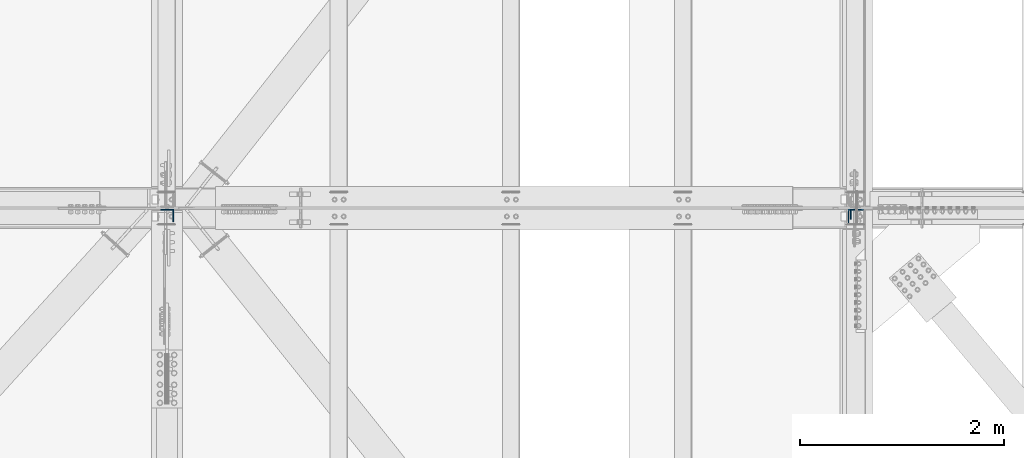
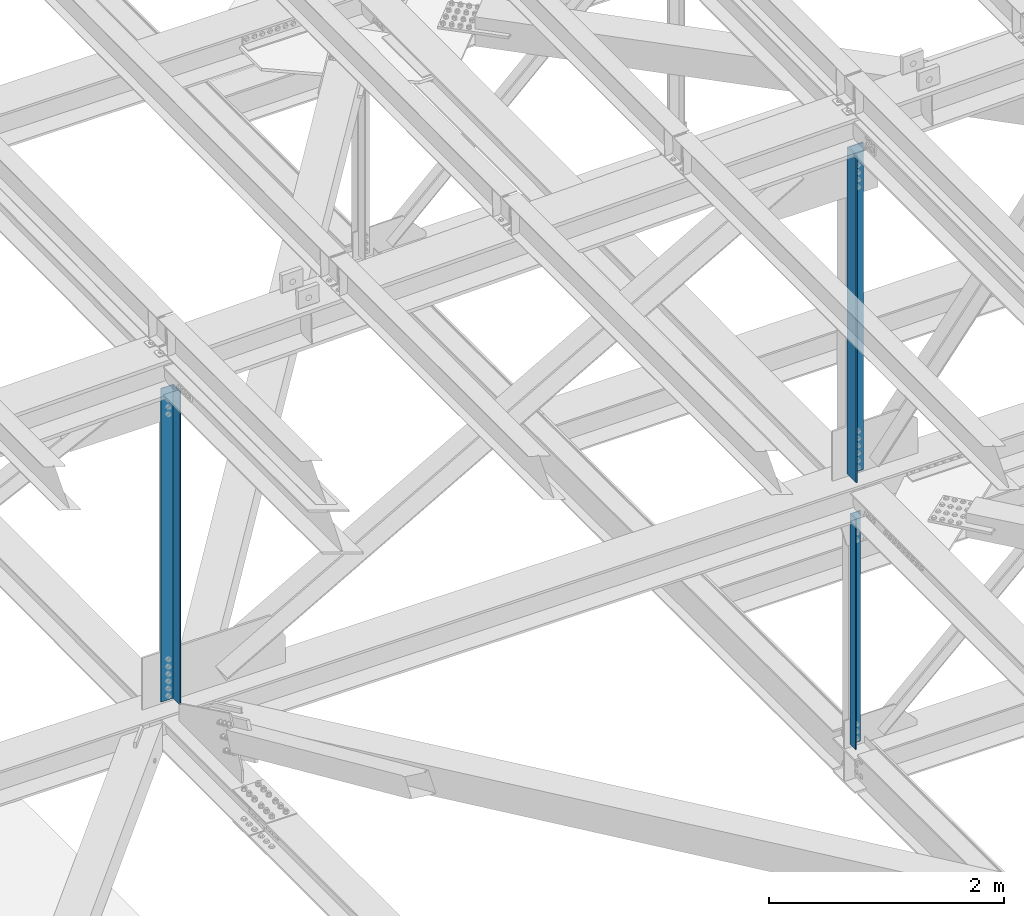
# One storey, part 1334 of 3843: 3 columns, 3 elements without a shape of their own.
"""IFC2X3 building model written with IfcOpenShell, lengths in millimetres."""

from ifc_helpers import new_model, si_unit, frame, origin_with_axes, place, context, subcontext, project, spatial, faceted_brep, material, type_object, element, aggregate, save


model = new_model("IFC2X3")

# Units and contexts
model_context = context("Model", 3, precision=1e-05, world=origin_with_axes())
body_context = subcontext(model_context, "Body", "Model", "MODEL_VIEW")
ifc_project = project(units=[si_unit("LENGTHUNIT", "METRE", prefix="MILLI"), si_unit("AREAUNIT", "SQUARE_METRE"), si_unit("VOLUMEUNIT", "CUBIC_METRE"), si_unit("MASSUNIT", "GRAM", prefix="KILO"), si_unit("TIMEUNIT", "SECOND"), si_unit("PLANEANGLEUNIT", "RADIAN"), si_unit("SOLIDANGLEUNIT", "STERADIAN"), si_unit("THERMODYNAMICTEMPERATUREUNIT", "DEGREE_CELSIUS"), si_unit("LUMINOUSINTENSITYUNIT", "LUMEN")], contexts=[model_context])

# Site, building, storey
site_placement = place(None, origin_with_axes())
site = spatial("IfcSite", under=ifc_project, at=site_placement, CompositionType="ELEMENT")
building_placement = place(site_placement, origin_with_axes())
building = spatial("IfcBuilding", under=site, at=building_placement, Name="Undefined", CompositionType="ELEMENT")
storey_placement = place(building_placement, origin_with_axes())
storey = spatial("IfcBuildingStorey", under=building, at=storey_placement, Name="Undefined", CompositionType="ELEMENT", Elevation=0.0)

# Assembly, column
assembly_1_placement = place(storey_placement, origin_with_axes())
assembly_1 = element("IfcElementAssembly", 1, at=assembly_1_placement, inside=storey, Name="ANGLE", AssemblyPlace="NOTDEFINED", PredefinedType="RIGID_FRAME")
ifc_material = material(Name="STEEL/A572-50")
column_type_1 = type_object("IfcColumnType", Name="L4X4X3/8", PredefinedType="NOTDEFINED")
column_1_placement = place(assembly_1_placement, frame((77012.8000000054, 33785.175, 39446.4754738793), z_axis=(0.0, -1.0, 0.0), x_axis=(0.0, 0.0, 1.0)))
column_1 = element("IfcColumn", 2, at=column_1_placement, type_object=column_type_1, material=ifc_material, Name="ANGLE", ObjectType="L4X4X3/8", context=body_context, shape_type="Brep", body=[
    faceted_brep([(216.00980325316, 50.8000000000029, -50.8000000000029), (216.00980325316, 50.8000000000029, 50.8000000000029), (2610.02346736631, 50.8000000000029, 50.8000000000029), (2610.02346736631, 50.8000000000029, -50.8000000000029), (216.00980325316, 41.2749999999942, 50.8000000000029), (2610.02346736631, 41.2749999999942, 50.8000000000029), (216.00980325316, 41.2749999999942, -41.2750000000015), (2610.02346736631, 41.2749999999942, -41.2750000000015), (216.00980325316, -50.8000000000029, -41.2750000000015), (2610.02346736631, -50.8000000000029, -41.2750000000015), (216.00980325316, -50.8000000000029, -50.8000000000029), (2610.02346736631, -50.8000000000029, -50.8000000000029)], [[[0, 1, 2, 3]], [[1, 4, 5, 2]], [[4, 6, 7, 5]], [[6, 8, 9, 7]], [[8, 10, 11, 9]], [[10, 0, 3, 11]], [[5, 7, 9, 11, 3, 2]], [[10, 8, 6, 4, 1, 0]]]),
])
aggregate(assembly_1, [column_1])

assembly_2_placement = place(storey_placement, origin_with_axes())
assembly_2 = element("IfcElementAssembly", 3, at=assembly_2_placement, inside=storey, Name="ANGLE", AssemblyPlace="NOTDEFINED", PredefinedType="RIGID_FRAME")
column_type_2 = type_object("IfcColumnType", Name="L6X6X1/2", PredefinedType="NOTDEFINED")
column_2_placement = place(assembly_2_placement, frame((77012.8000000005, 33759.775, 42266.073495852), z_axis=(0.0, -1.0, 0.0), x_axis=(0.0, 0.0, 1.0)))
column_2 = element("IfcColumn", 4, at=column_2_placement, type_object=column_type_2, material=ifc_material, Name="ANGLE", ObjectType="L6X6X1/2", context=body_context, shape_type="Brep", body=[
    faceted_brep([(208.907442296171, 76.1999999999971, -76.1999999999971), (208.907442296171, 76.1999999999971, 76.1999999999971), (3606.3579882966, 76.1999999999971, 76.1999999999971), (3606.3579882966, 76.1999999999971, -76.1999999999971), (208.907442296171, 63.5, 76.1999999999971), (3606.3579882966, 63.5, 76.1999999999971), (208.907442296171, 63.5, -63.5), (3606.3579882966, 63.5, -63.5), (208.907442296171, -76.1999999999971, -63.5), (3606.3579882966, -76.1999999999971, -63.5), (208.907442296171, -76.1999999999971, -76.1999999999971), (3606.3579882966, -76.1999999999971, -76.1999999999971)], [[[0, 1, 2, 3]], [[1, 4, 5, 2]], [[4, 6, 7, 5]], [[6, 8, 9, 7]], [[8, 10, 11, 9]], [[10, 0, 3, 11]], [[5, 7, 9, 11, 3, 2]], [[10, 8, 6, 4, 1, 0]]]),
])
aggregate(assembly_2, [column_2])

assembly_3_placement = place(storey_placement, origin_with_axes())
assembly_3 = element("IfcElementAssembly", 5, at=assembly_3_placement, inside=storey, Name="ANGLE", AssemblyPlace="NOTDEFINED", PredefinedType="RIGID_FRAME")
column_type_3 = type_object("IfcColumnType", Name="L5X5X3/8", PredefinedType="NOTDEFINED")
column_3_placement = place(assembly_3_placement, frame((70256.4000000689, 33772.475, 42262.8113963359), z_axis=(-1.0, 0.0, 0.0), x_axis=(0.0, 0.0, 1.0)))
column_3 = element("IfcColumn", 6, at=column_3_placement, type_object=column_type_3, material=ifc_material, Name="ANGLE", ObjectType="L5X5X3/8", context=body_context, shape_type="Brep", body=[
    faceted_brep([(209.381434355899, 63.5, -63.5), (209.381434355899, 63.5, 63.5), (3464.48447721272, 63.5, 63.5), (3464.48447721272, 63.5, -63.5), (209.381434355899, 53.9749999999985, 63.5), (3464.48447721272, 53.9749999999985, 63.5), (209.381434355899, 53.9749999999985, -53.9750000000058), (3464.48447721272, 53.9749999999985, -53.9750000000058), (209.381434355899, -63.5, -53.9750000000058), (3464.48447721272, -63.5, -53.9750000000058), (209.381434355899, -63.5, -63.5), (3464.48447721272, -63.5, -63.5)], [[[0, 1, 2, 3]], [[1, 4, 5, 2]], [[4, 6, 7, 5]], [[6, 8, 9, 7]], [[8, 10, 11, 9]], [[10, 0, 3, 11]], [[5, 7, 9, 11, 3, 2]], [[10, 8, 6, 4, 1, 0]]]),
])
aggregate(assembly_3, [column_3])

save(model, "model.ifc")
